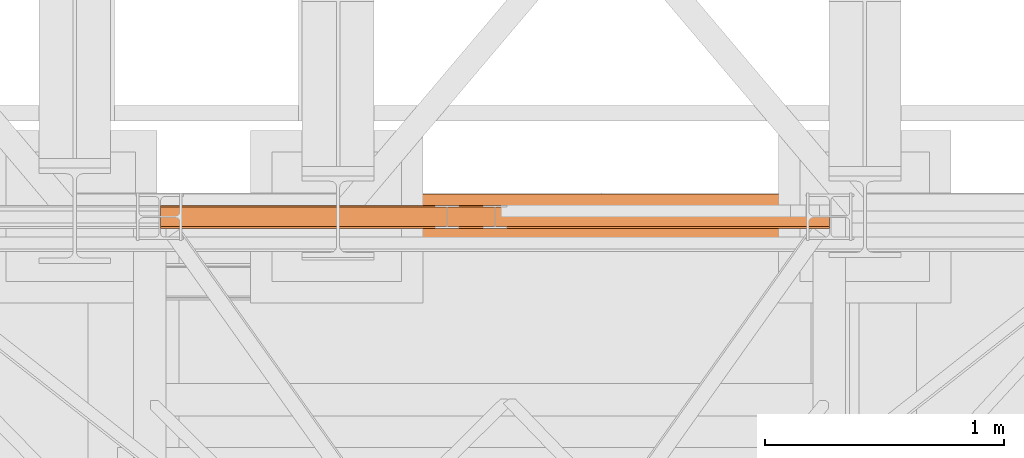
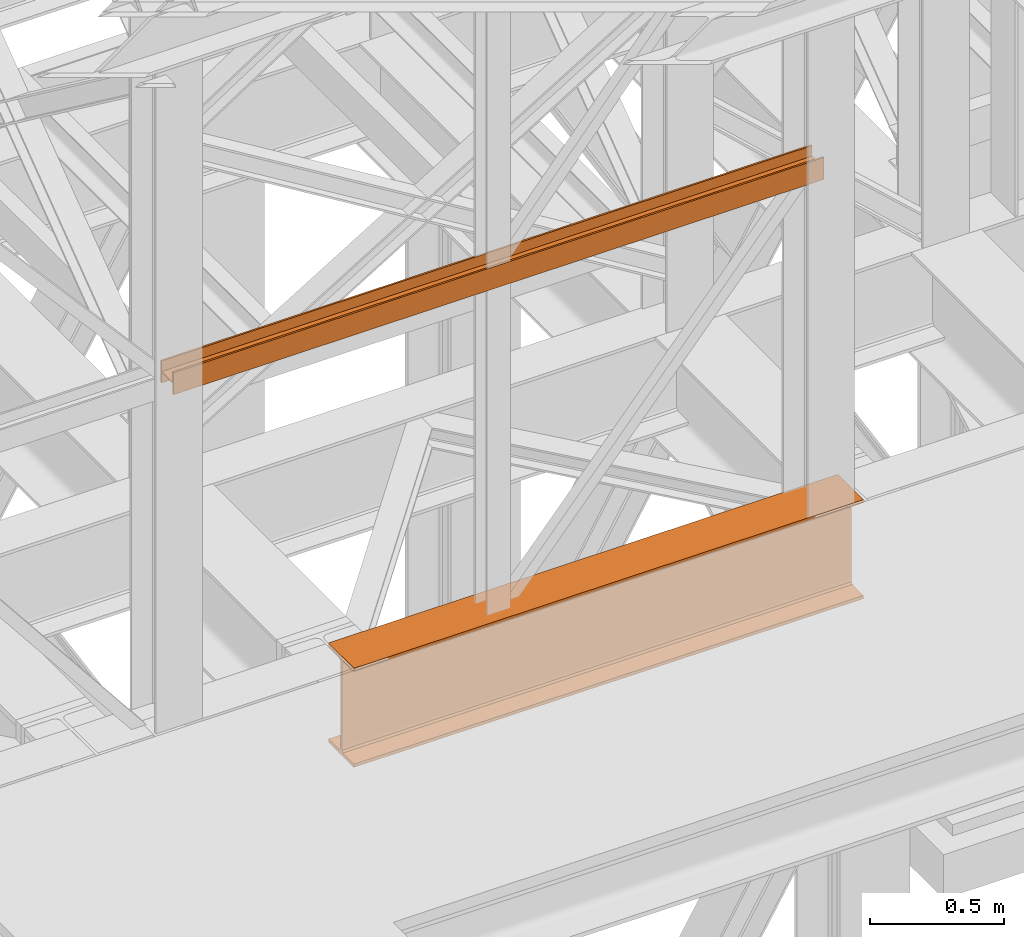
# One storey, part 72 of 208: 2 proxies.
"""IFC2X3 building model written with IfcOpenShell, lengths in millimetres."""

from ifc_helpers import new_model, entity, si_unit, converted_unit, frame, origin, origin_with_axes, place, context, subcontext, project, spatial, faceted_brep, element, save


model = new_model("IFC2X3")

# Units and contexts
model_context = context("Model", 3, precision=1e-05, world=origin())
plan_context = context("Plan", 3, precision=1e-05, world=origin())
body_context = subcontext(model_context, "Body", "Model", "MODEL_VIEW")
ifc_project = project(units=[si_unit("LENGTHUNIT", "METRE", prefix="MILLI"), converted_unit("PLANEANGLEUNIT", "DEGREE", entity("IfcPlaneAngleMeasure", 0.0174532925199433), si_unit("PLANEANGLEUNIT", "RADIAN"), dimensions=[0, 0, 0, 0, 0, 0, 0]), si_unit("AREAUNIT", "SQUARE_METRE"), si_unit("VOLUMEUNIT", "CUBIC_METRE")], contexts=[model_context, plan_context])

# Building, storey
building_placement = place(None, origin())
building = spatial("IfcBuilding", under=ifc_project, at=building_placement, CompositionType="COMPLEX")
storey_placement = place(building_placement, origin_with_axes())
storey = spatial("IfcBuildingStorey", under=building, at=storey_placement, Name="Geschoss", CompositionType="ELEMENT")

# Proxies
proxy_1_placement = place(storey_placement, frame((3299.254968580828, -17357.574399786, 4834.989987483023), z_axis=(0.0, 0.0, 1.0), x_axis=(1.0, 0.0, 0.0)))
element("IfcBuildingElementProxy", 1, at=proxy_1_placement, inside=storey, context=body_context, shape_type="Brep", body=[
    faceted_brep([(2188.009999895692, 0.00999999999839929, 450.0100178813937), (2188.009999895692, 190.0100125169738, 450.0100178813937), (2188.009999895692, 190.0100125169738, 435.4100240564349), (2188.009999895692, 120.7100073045476, 435.4100091552737), (2188.009999895692, 109.8415622657522, 433.2347078418734), (2188.009999895692, 101.8853126263603, 425.2784563398363), (2188.009999895692, 99.71000619068582, 414.4100113010409), (2188.009999895692, 99.71000619068582, 35.60999167919181), (2188.009999895692, 101.8853126263603, 24.74154664039634), (2188.009999895692, 109.8415622657522, 16.78529513835929), (2188.009999895692, 120.7100073045476, 14.60999382495902), (2188.009999895692, 190.0100125169738, 14.60999382495902), (2188.009999895692, 190.0100125169738, 0.01000000000021828), (2188.009999895692, 0.00999999999839929, 0.01000000000021828), (2188.009999895692, 0.00999999999839929, 14.60999382495902), (2188.009999895692, 69.31000521242458, 14.60999382495902), (2188.009999895692, 80.17845025122006, 16.78529513835929), (2188.009999895692, 88.13469989061196, 24.74154664039634), (2188.009999895692, 90.31000632628638, 35.60999167919181), (2188.009999895692, 90.31000632628638, 414.4100113010409), (2188.009999895692, 88.13469989061196, 425.2784563398363), (2188.009999895692, 80.17845025122006, 433.2347078418734), (2188.009999895692, 69.31000521242458, 435.4100091552737), (2188.009999895692, 0.00999999999839929, 435.4100240564349), (2188.009999895692, 190.0100125169738, 450.0100178813937), (2188.009999895692, 0.00999999999839929, 450.0100178813937), (0.01000000000021828, 0.00999999999839929, 450.0100178813937), (0.01000000000021828, 190.0100125169738, 450.0100178813937), (2188.009999895692, 190.0100125169738, 435.4100240564349), (2188.009999895692, 190.0100125169738, 450.0100178813937), (0.01000000000021828, 190.0100125169738, 450.0100178813937), (0.01000000000021828, 190.0100125169738, 435.4100240564349), (2188.009999895692, 120.7100073045476, 435.4100091552737), (2188.009999895692, 190.0100125169738, 435.4100240564349), (0.01000000000021828, 190.0100125169738, 435.4100240564349), (0.01000000000021828, 120.7100073045476, 435.4100091552737), (2188.009999895692, 109.8415622657522, 433.2347078418734), (2188.009999895692, 120.7100073045476, 435.4100091552737), (0.01000000000021828, 120.7100073045476, 435.4100091552737), (0.01000000000021828, 109.8415622657522, 433.2347078418734), (2188.009999895692, 101.8853126263603, 425.2784563398363), (2188.009999895692, 109.8415622657522, 433.2347078418734), (0.01000000000021828, 109.8415622657522, 433.2347078418734), (0.01000000000021828, 101.8853126263603, 425.2784563398363), (2188.009999895692, 99.71000619068582, 414.4100113010409), (2188.009999895692, 101.8853126263603, 425.2784563398363), (0.01000000000021828, 101.8853126263603, 425.2784563398363), (0.01000000000021828, 99.71000619068582, 414.4100113010409), (2188.009999895692, 99.71000619068582, 35.60999167919181), (2188.009999895692, 99.71000619068582, 414.4100113010409), (0.01000000000021828, 99.71000619068582, 414.4100113010409), (0.01000000000021828, 99.71000619068582, 35.60999167919181), (2188.009999895692, 101.8853126263603, 24.74154664039634), (2188.009999895692, 99.71000619068582, 35.60999167919181), (0.01000000000021828, 99.71000619068582, 35.60999167919181), (0.01000000000021828, 101.8853126263603, 24.74154664039634), (2188.009999895692, 109.8415622657522, 16.78529513835929), (2188.009999895692, 101.8853126263603, 24.74154664039634), (0.01000000000021828, 101.8853126263603, 24.74154664039634), (0.01000000000021828, 109.8415622657522, 16.78529513835929), (2188.009999895692, 120.7100073045476, 14.60999382495902), (2188.009999895692, 109.8415622657522, 16.78529513835929), (0.01000000000021828, 109.8415622657522, 16.78529513835929), (0.01000000000021828, 120.7100073045476, 14.60999382495902), (2188.009999895692, 190.0100125169738, 14.60999382495902), (2188.009999895692, 120.7100073045476, 14.60999382495902), (0.01000000000021828, 120.7100073045476, 14.60999382495902), (0.01000000000021828, 190.0100125169738, 14.60999382495902), (2188.009999895692, 190.0100125169738, 0.01000000000021828), (2188.009999895692, 190.0100125169738, 14.60999382495902), (0.01000000000021828, 190.0100125169738, 14.60999382495902), (0.01000000000021828, 190.0100125169738, 0.01000000000021828), (2188.009999895692, 0.00999999999839929, 0.01000000000021828), (2188.009999895692, 190.0100125169738, 0.01000000000021828), (0.01000000000021828, 190.0100125169738, 0.01000000000021828), (0.01000000000021828, 0.00999999999839929, 0.01000000000021828), (2188.009999895692, 0.00999999999839929, 14.60999382495902), (2188.009999895692, 0.00999999999839929, 0.01000000000021828), (0.01000000000021828, 0.00999999999839929, 0.01000000000021828), (0.01000000000021828, 0.00999999999839929, 14.60999382495902), (2188.009999895692, 69.31000521242458, 14.60999382495902), (2188.009999895692, 0.00999999999839929, 14.60999382495902), (0.01000000000021828, 0.00999999999839929, 14.60999382495902), (0.01000000000021828, 69.31000521242458, 14.60999382495902), (2188.009999895692, 80.17845025122006, 16.78529513835929), (2188.009999895692, 69.31000521242458, 14.60999382495902), (0.01000000000021828, 69.31000521242458, 14.60999382495902), (0.01000000000021828, 80.17845025122006, 16.78529513835929), (2188.009999895692, 88.13469989061196, 24.74154664039634), (2188.009999895692, 80.17845025122006, 16.78529513835929), (0.01000000000021828, 80.17845025122006, 16.78529513835929), (0.01000000000021828, 88.13469989061196, 24.74154664039634), (2188.009999895692, 90.31000632628638, 35.60999167919181), (2188.009999895692, 88.13469989061196, 24.74154664039634), (0.01000000000021828, 88.13469989061196, 24.74154664039634), (0.01000000000021828, 90.31000632628638, 35.60999167919181), (2188.009999895692, 90.31000632628638, 414.4100113010409), (2188.009999895692, 90.31000632628638, 35.60999167919181), (0.01000000000021828, 90.31000632628638, 35.60999167919181), (0.01000000000021828, 90.31000632628638, 414.4100113010409), (2188.009999895692, 88.13469989061196, 425.2784563398363), (2188.009999895692, 90.31000632628638, 414.4100113010409), (0.01000000000021828, 90.31000632628638, 414.4100113010409), (0.01000000000021828, 88.13469989061196, 425.2784563398363), (2188.009999895692, 80.17845025122006, 433.2347078418734), (2188.009999895692, 88.13469989061196, 425.2784563398363), (0.01000000000021828, 88.13469989061196, 425.2784563398363), (0.01000000000021828, 80.17845025122006, 433.2347078418734), (2188.009999895692, 69.31000521242458, 435.4100091552737), (2188.009999895692, 80.17845025122006, 433.2347078418734), (0.01000000000021828, 80.17845025122006, 433.2347078418734), (0.01000000000021828, 69.31000521242458, 435.4100091552737), (2188.009999895692, 0.00999999999839929, 435.4100240564349), (2188.009999895692, 69.31000521242458, 435.4100091552737), (0.01000000000021828, 69.31000521242458, 435.4100091552737), (0.01000000000021828, 0.00999999999839929, 435.4100240564349), (2188.009999895692, 0.00999999999839929, 450.0100178813937), (2188.009999895692, 0.00999999999839929, 435.4100240564349), (0.01000000000021828, 0.00999999999839929, 435.4100240564349), (0.01000000000021828, 0.00999999999839929, 450.0100178813937), (0.01000000000021828, 0.00999999999839929, 450.0100178813937), (0.01000000000021828, 0.00999999999839929, 435.4100240564349), (0.01000000000021828, 69.31000521242458, 435.4100091552737), (0.01000000000021828, 80.17845025122006, 433.2347078418734), (0.01000000000021828, 88.13469989061196, 425.2784563398363), (0.01000000000021828, 90.31000632628638, 414.4100113010409), (0.01000000000021828, 90.31000632628638, 35.60999167919181), (0.01000000000021828, 88.13469989061196, 24.74154664039634), (0.01000000000021828, 80.17845025122006, 16.78529513835929), (0.01000000000021828, 69.31000521242458, 14.60999382495902), (0.01000000000021828, 0.00999999999839929, 14.60999382495902), (0.01000000000021828, 0.00999999999839929, 0.01000000000021828), (0.01000000000021828, 190.0100125169738, 0.01000000000021828), (0.01000000000021828, 190.0100125169738, 14.60999382495902), (0.01000000000021828, 120.7100073045476, 14.60999382495902), (0.01000000000021828, 109.8415622657522, 16.78529513835929), (0.01000000000021828, 101.8853126263603, 24.74154664039634), (0.01000000000021828, 99.71000619068582, 35.60999167919181), (0.01000000000021828, 99.71000619068582, 414.4100113010409), (0.01000000000021828, 101.8853126263603, 425.2784563398363), (0.01000000000021828, 109.8415622657522, 433.2347078418734), (0.01000000000021828, 120.7100073045476, 435.4100091552737), (0.01000000000021828, 190.0100125169738, 435.4100240564349), (0.01000000000021828, 190.0100125169738, 450.0100178813937)], [[[0, 1, 2, 3, 4, 5, 6, 7, 8, 9, 10, 11, 12, 13, 14, 15, 16, 17, 18, 19, 20, 21, 22, 23]], [[24, 25, 26, 27]], [[28, 29, 30, 31]], [[32, 33, 34, 35]], [[36, 37, 38, 39]], [[40, 41, 42, 43]], [[44, 45, 46, 47]], [[48, 49, 50, 51]], [[52, 53, 54, 55]], [[56, 57, 58, 59]], [[60, 61, 62, 63]], [[64, 65, 66, 67]], [[68, 69, 70, 71]], [[72, 73, 74, 75]], [[76, 77, 78, 79]], [[80, 81, 82, 83]], [[84, 85, 86, 87]], [[88, 89, 90, 91]], [[92, 93, 94, 95]], [[96, 97, 98, 99]], [[100, 101, 102, 103]], [[104, 105, 106, 107]], [[108, 109, 110, 111]], [[112, 113, 114, 115]], [[116, 117, 118, 119]], [[120, 121, 122, 123, 124, 125, 126, 127, 128, 129, 130, 131, 132, 133, 134, 135, 136, 137, 138, 139, 140, 141, 142, 143]]], orient=[[False], [False], [False], [False], [False], [False], [False], [False], [False], [False], [False], [False], [False], [False], [False], [False], [False], [False], [False], [False], [False], [False], [False], [False], [False], [False]]),
])
proxy_2_placement = place(storey_placement, frame((2551.504968595722, -17310.57438993344, 6759.989999254943), z_axis=(0.0, 0.0, 1.0), x_axis=(1.0, 0.0, 0.0)))
element("IfcBuildingElementProxy", 2, at=proxy_2_placement, inside=storey, context=body_context, shape_type="Brep", body=[
    faceted_brep([(0.01000000000021828, 88.0099999999984, 0.01000000000021828), (0.01000000000021828, 96.0099999999984, 0.01000000000021828), (0.01000000000021828, 96.0099999999984, 100.0100000000002), (0.01000000000021828, 88.0099999999984, 100.0100000000002), (0.01000000000021828, 88.0099999999984, 52.51000000000022), (0.01000000000021828, 8.0099999999984, 52.51000000000022), (0.01000000000021828, 8.0099999999984, 100.0100000000002), (0.01000000000021828, 0.00999999999839929, 100.0100000000002), (0.01000000000021828, 0.00999999999839929, 0.01000000000021828), (0.01000000000021828, 8.0099999999984, 0.01000000000021828), (0.01000000000021828, 8.0099999999984, 47.51000000000022), (0.01000000000021828, 88.0099999999984, 47.51000000000022), (0.01000000000021828, 96.0099999999984, 0.01000000000021828), (0.01000000000021828, 88.0099999999984, 0.01000000000021828), (2793.50999986589, 88.0099999999984, 0.01000000000021828), (2793.50999986589, 96.0099999999984, 0.01000000000021828), (0.01000000000021828, 96.0099999999984, 100.0100000000002), (0.01000000000021828, 96.0099999999984, 0.01000000000021828), (2793.50999986589, 96.0099999999984, 0.01000000000021828), (2793.50999986589, 96.0099999999984, 100.0100000000002), (0.01000000000021828, 88.0099999999984, 100.0100000000002), (0.01000000000021828, 96.0099999999984, 100.0100000000002), (2793.50999986589, 96.0099999999984, 100.0100000000002), (2793.50999986589, 88.0099999999984, 100.0100000000002), (0.01000000000021828, 88.0099999999984, 52.51000000000022), (0.01000000000021828, 88.0099999999984, 100.0100000000002), (2793.50999986589, 88.0099999999984, 100.0100000000002), (2793.50999986589, 88.0099999999984, 52.51000000000022), (0.01000000000021828, 8.0099999999984, 52.51000000000022), (0.01000000000021828, 88.0099999999984, 52.51000000000022), (2793.50999986589, 88.0099999999984, 52.51000000000022), (2793.50999986589, 8.0099999999984, 52.51000000000022), (0.01000000000021828, 8.0099999999984, 100.0100000000002), (0.01000000000021828, 8.0099999999984, 52.51000000000022), (2793.50999986589, 8.0099999999984, 52.51000000000022), (2793.50999986589, 8.0099999999984, 100.0100000000002), (0.01000000000021828, 0.00999999999839929, 100.0100000000002), (0.01000000000021828, 8.0099999999984, 100.0100000000002), (2793.50999986589, 8.0099999999984, 100.0100000000002), (2793.50999986589, 0.00999999999839929, 100.0100000000002), (0.01000000000021828, 0.00999999999839929, 0.01000000000021828), (0.01000000000021828, 0.00999999999839929, 100.0100000000002), (2793.50999986589, 0.00999999999839929, 100.0100000000002), (2793.50999986589, 0.00999999999839929, 0.01000000000021828), (0.01000000000021828, 8.0099999999984, 0.01000000000021828), (0.01000000000021828, 0.00999999999839929, 0.01000000000021828), (2793.50999986589, 0.00999999999839929, 0.01000000000021828), (2793.50999986589, 8.0099999999984, 0.01000000000021828), (0.01000000000021828, 8.0099999999984, 47.51000000000022), (0.01000000000021828, 8.0099999999984, 0.01000000000021828), (2793.50999986589, 8.0099999999984, 0.01000000000021828), (2793.50999986589, 8.0099999999984, 47.51000000000022), (0.01000000000021828, 88.0099999999984, 47.51000000000022), (0.01000000000021828, 8.0099999999984, 47.51000000000022), (2793.50999986589, 8.0099999999984, 47.51000000000022), (2793.50999986589, 88.0099999999984, 47.51000000000022), (0.01000000000021828, 88.0099999999984, 0.01000000000021828), (0.01000000000021828, 88.0099999999984, 47.51000000000022), (2793.50999986589, 88.0099999999984, 47.51000000000022), (2793.50999986589, 88.0099999999984, 0.01000000000021828), (2793.50999986589, 88.0099999999984, 0.01000000000021828), (2793.50999986589, 88.0099999999984, 47.51000000000022), (2793.50999986589, 8.0099999999984, 47.51000000000022), (2793.50999986589, 8.0099999999984, 0.01000000000021828), (2793.50999986589, 0.00999999999839929, 0.01000000000021828), (2793.50999986589, 0.00999999999839929, 100.0100000000002), (2793.50999986589, 8.0099999999984, 100.0100000000002), (2793.50999986589, 8.0099999999984, 52.51000000000022), (2793.50999986589, 88.0099999999984, 52.51000000000022), (2793.50999986589, 88.0099999999984, 100.0100000000002), (2793.50999986589, 96.0099999999984, 100.0100000000002), (2793.50999986589, 96.0099999999984, 0.01000000000021828)], [[[0, 1, 2, 3, 4, 5, 6, 7, 8, 9, 10, 11]], [[12, 13, 14, 15]], [[16, 17, 18, 19]], [[20, 21, 22, 23]], [[24, 25, 26, 27]], [[28, 29, 30, 31]], [[32, 33, 34, 35]], [[36, 37, 38, 39]], [[40, 41, 42, 43]], [[44, 45, 46, 47]], [[48, 49, 50, 51]], [[52, 53, 54, 55]], [[56, 57, 58, 59]], [[60, 61, 62, 63, 64, 65, 66, 67, 68, 69, 70, 71]]], orient=[[False], [False], [False], [False], [False], [False], [False], [False], [False], [False], [False], [False], [False], [False]]),
])

save(model, "model.ifc")
